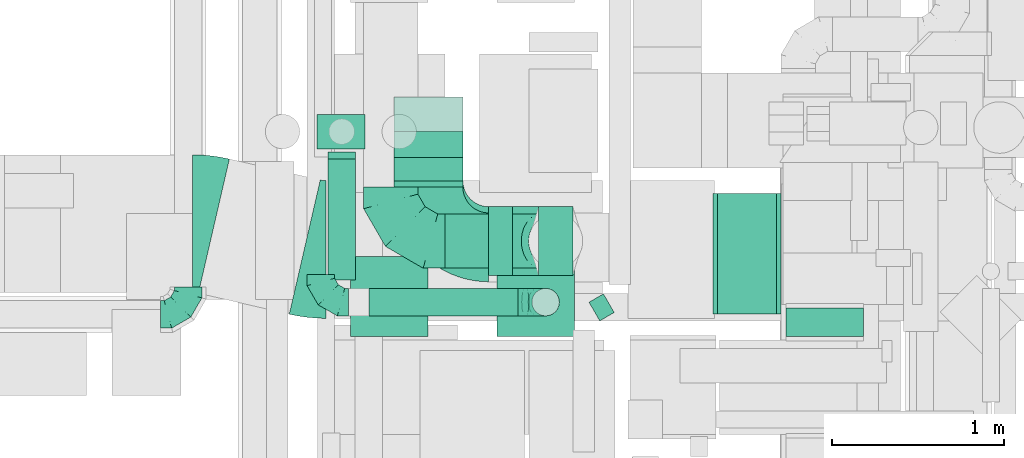
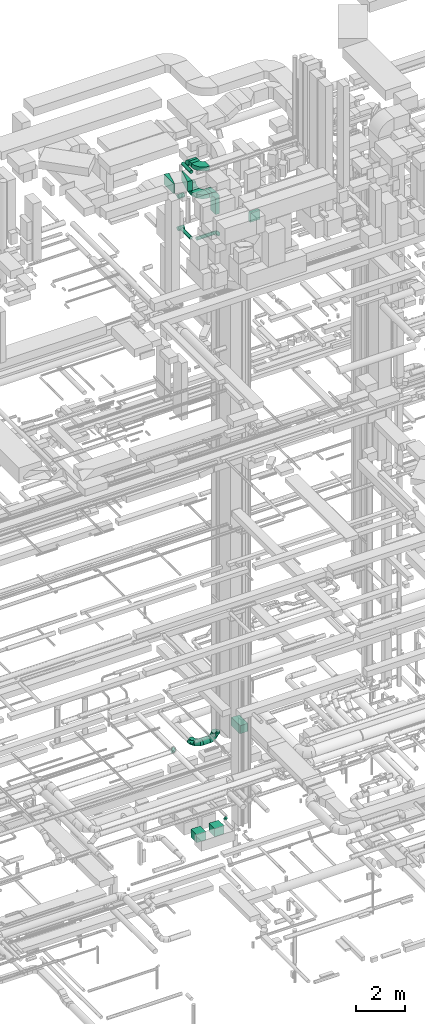
# One storey, part 176 of 337: 15 flow fittings, 15 flow segments.
"""IFC2X3 building model written with IfcOpenShell, lengths in millimetres."""

from ifc_helpers import new_model, entity, si_unit, converted_unit, derived_unit, direction, frame, frame_2d, origin, origin_2d_with_axis, place, context, subcontext, project, spatial, polyline, circle_curve, parameter, trimmed, segment, composite_curve, rectangle, circle, outline, extrude, faceted_brep, source, transform, mapped, material, type_object, type_shapes, element, save


model = new_model("IFC2X3")

# Units and contexts
model_context = context("Model", 3, precision=0.01, world=origin(), true_north=direction((6.12303176911189e-17, 1.0)))
body_context = subcontext(model_context, "Body", "Model", "MODEL_VIEW")
ifc_project = project(units=[si_unit("LENGTHUNIT", "METRE", prefix="MILLI"), si_unit("AREAUNIT", "SQUARE_METRE"), si_unit("VOLUMEUNIT", "CUBIC_METRE"), converted_unit("PLANEANGLEUNIT", "DEGREE", entity("IfcRatioMeasure", 0.0174532925199433), si_unit("PLANEANGLEUNIT", "RADIAN"), dimensions=[0, 0, 0, 0, 0, 0, 0]), si_unit("MASSUNIT", "GRAM", prefix="KILO"), derived_unit("MASSDENSITYUNIT", [(si_unit("MASSUNIT", "GRAM", prefix="KILO"), 1), (si_unit("LENGTHUNIT", "METRE"), -3)]), derived_unit("MOMENTOFINERTIAUNIT", [(si_unit("LENGTHUNIT", "METRE"), 4)]), si_unit("TIMEUNIT", "SECOND"), si_unit("FREQUENCYUNIT", "HERTZ"), si_unit("THERMODYNAMICTEMPERATUREUNIT", "DEGREE_CELSIUS"), derived_unit("THERMALTRANSMITTANCEUNIT", [(si_unit("MASSUNIT", "GRAM", prefix="KILO"), 1), (si_unit("THERMODYNAMICTEMPERATUREUNIT", "KELVIN"), -1), (si_unit("TIMEUNIT", "SECOND"), -3)]), derived_unit("VOLUMETRICFLOWRATEUNIT", [(si_unit("LENGTHUNIT", "METRE"), 3), (si_unit("TIMEUNIT", "SECOND"), -1)]), derived_unit("MASSFLOWRATEUNIT", [(si_unit("MASSUNIT", "GRAM", prefix="KILO"), 1), (si_unit("TIMEUNIT", "SECOND"), -1)]), derived_unit("ROTATIONALFREQUENCYUNIT", [(si_unit("TIMEUNIT", "SECOND"), -1)]), si_unit("ELECTRICCURRENTUNIT", "AMPERE"), si_unit("ELECTRICVOLTAGEUNIT", "VOLT"), si_unit("POWERUNIT", "WATT"), si_unit("FORCEUNIT", "NEWTON", prefix="KILO"), si_unit("ILLUMINANCEUNIT", "LUX"), si_unit("LUMINOUSFLUXUNIT", "LUMEN"), si_unit("LUMINOUSINTENSITYUNIT", "CANDELA"), derived_unit("USERDEFINED", [(si_unit("MASSUNIT", "GRAM", prefix="KILO"), -1), (si_unit("LENGTHUNIT", "METRE"), -2), (si_unit("TIMEUNIT", "SECOND"), 3), (si_unit("LUMINOUSFLUXUNIT", "LUMEN"), 1)]), derived_unit("LINEARVELOCITYUNIT", [(si_unit("LENGTHUNIT", "METRE"), 1), (si_unit("TIMEUNIT", "SECOND"), -1)]), si_unit("PRESSUREUNIT", "PASCAL"), derived_unit("USERDEFINED", [(si_unit("LENGTHUNIT", "METRE"), -2), (si_unit("MASSUNIT", "GRAM", prefix="KILO"), 1), (si_unit("TIMEUNIT", "SECOND"), -2)]), derived_unit("LINEARFORCEUNIT", [(si_unit("MASSUNIT", "GRAM", prefix="KILO"), 1), (si_unit("LENGTHUNIT", "METRE"), 1), (si_unit("TIMEUNIT", "SECOND"), -2), (si_unit("LENGTHUNIT", "METRE"), -1)]), derived_unit("PLANARFORCEUNIT", [(si_unit("MASSUNIT", "GRAM", prefix="KILO"), 1), (si_unit("LENGTHUNIT", "METRE"), 1), (si_unit("TIMEUNIT", "SECOND"), -2), (si_unit("LENGTHUNIT", "METRE"), -2)])], contexts=[model_context])

# Site, building, storey
site_placement = place(None, origin())
site = spatial("IfcSite", under=ifc_project, at=site_placement, CompositionType="ELEMENT")
building_placement = place(site_placement, origin())
building = spatial("IfcBuilding", under=site, at=building_placement, CompositionType="ELEMENT")
storey_placement = place(building_placement, origin())
storey = spatial("IfcBuildingStorey", under=building, at=storey_placement, CompositionType="ELEMENT", Elevation=0.0)

# Flow segments
duct_segment_type_1 = type_object("IfcDuctSegmentType", PredefinedType="NOTDEFINED")
flow_segment_1_placement = place(storey_placement, frame((44232.27, 11784.6, -1300.0)))
element("IfcFlowSegment", 1, at=flow_segment_1_placement, inside=storey, type_object=duct_segment_type_1, context=body_context, shape_type="SweptSolid", body=[
    extrude(rectangle(XDim=463.717020003643, YDim=450.000000000002, at=origin_2d_with_axis()), frame((225.0, 231.86, 0.0), z_axis=(0.0, 0.0, 1.0), x_axis=(0.0, 1.0, 0.0)), (0.0, 0.0, 1.0), 400.0),
])
flow_segment_2_placement = place(storey_placement, frame((43382.27, 11784.6, -1300.0)))
element("IfcFlowSegment", 2, at=flow_segment_2_placement, inside=storey, type_object=duct_segment_type_1, context=body_context, shape_type="SweptSolid", body=[
    extrude(rectangle(XDim=463.717020003613, YDim=450.000000000002, at=origin_2d_with_axis()), frame((225.0, 231.86, 0.0), z_axis=(0.0, 0.0, 1.0), x_axis=(0.0, 1.0, 0.0)), (0.0, 0.0, 1.0), 400.0),
])
flow_segment_3_placement = place(storey_placement, frame((45515.05, 11913.72, 3300.0)))
element("IfcFlowSegment", 3, at=flow_segment_3_placement, inside=storey, type_object=duct_segment_type_1, context=body_context, shape_type="SweptSolid", body=[
    extrude(rectangle(XDim=340.793808090526, YDim=700.000000000001, at=origin_2d_with_axis()), frame((170.4, 350.0, 0.0)), (0.0, 0.0, 1.0), 400.0),
])
flow_segment_4_placement = place(storey_placement, frame((44473.69, 12138.29, 29350.24)))
element("IfcFlowSegment", 4, at=flow_segment_4_placement, inside=storey, type_object=duct_segment_type_1, context=body_context, shape_type="SweptSolid", body=[
    extrude(rectangle(XDim=400.0, YDim=199.999999999998, at=origin_2d_with_axis()), frame((100.0, 200.0, 0.0), z_axis=(0.0, 0.0, 1.0), x_axis=(0.0, -1.0, 0.0)), (0.0, 0.0, 1.0), 799.758299470746),
])
flow_segment_5_placement = place(storey_placement, frame((44185.05, 12138.29, 30300.0)))
element("IfcFlowSegment", 5, at=flow_segment_5_placement, inside=storey, type_object=duct_segment_type_1, context=body_context, shape_type="SweptSolid", body=[
    extrude(rectangle(XDim=138.646095000015, YDim=400.0, at=origin_2d_with_axis()), frame((69.32, 200.0, 0.0), z_axis=(0.0, 0.0, 1.0), x_axis=(-1.0, 0.0, 0.0)), (0.0, 0.0, 1.0), 199.999999999998),
])
flow_segment_6_placement = place(storey_placement, frame((43635.05, 12688.29, 30300.0)))
element("IfcFlowSegment", 6, at=flow_segment_6_placement, inside=storey, type_object=duct_segment_type_1, context=body_context, shape_type="SweptSolid", body=[
    extrude(rectangle(XDim=136.304100000002, YDim=400.000000000004, at=origin_2d_with_axis()), frame((200.0, 68.15, 0.0), z_axis=(0.0, 0.0, 1.0), x_axis=(0.0, 1.0, 0.0)), (0.0, 0.0, 1.0), 199.999999999998),
])
flow_segment_7_placement = place(storey_placement, frame((43635.05, 12651.84, 31700.0)))
element("IfcFlowSegment", 7, at=flow_segment_7_placement, inside=storey, type_object=duct_segment_type_1, context=body_context, shape_type="SweptSolid", body=[
    extrude(rectangle(XDim=172.721155544705, YDim=399.999999999996, at=origin_2d_with_axis()), frame((200.01, 86.39, 0.0), z_axis=(0.0, 0.0, 1.0), x_axis=(0.000143096276811806, -0.999999989761728, 0.0)), (0.0, 0.0, 1.0), 199.999999999998),
])
flow_segment_8_placement = place(storey_placement, frame((45911.4, 11784.6, 28680.0)))
element("IfcFlowSegment", 8, at=flow_segment_8_placement, inside=storey, type_object=duct_segment_type_1, context=body_context, shape_type="SweptSolid", body=[
    extrude(rectangle(XDim=165.999999999997, YDim=450.000000000002, at=origin_2d_with_axis()), frame((225.0, 83.0, 0.0), z_axis=(0.0, 0.0, 1.0), x_axis=(0.0, -1.0, 0.0)), (0.0, 0.0, 1.0), 450.000000000002),
])
duct_segment_type_2 = type_object("IfcDuctSegmentType", PredefinedType="NOTDEFINED")
flow_segment_9_placement = place(storey_placement, frame((44765.88, 11873.59, -764.1)))
element("IfcFlowSegment", 9, at=flow_segment_9_placement, inside=storey, type_object=duct_segment_type_2, context=body_context, shape_type="SweptSolid", body=[
    extrude(circle(Radius=62.5, at=origin_2d_with_axis()), frame((32.85, 55.72, 64.1), z_axis=(0.866025210844138, 0.500000334182255, 0.0), x_axis=(0.500000334182255, -0.866025210844138, 0.0)), (0.0, 0.0, 1.0), 96.8997079406681),
])
flow_segment_10_placement = place(storey_placement, frame((43931.18, 12179.19, 3040.9)))
element("IfcFlowSegment", 10, at=flow_segment_10_placement, inside=storey, type_object=duct_segment_type_2, context=body_context, shape_type="SweptSolid", body=[
    extrude(circle(Radius=157.5, at=origin_2d_with_axis()), frame((0.0, 159.1, 159.1), z_axis=(1.0, 0.0, 0.0), x_axis=(0.0, -1.0, 0.0)), (0.0, 0.0, 1.0), 327.509169479983),
])
flow_segment_11_placement = place(storey_placement, frame((43249.45, 12113.77, 31818.4)))
element("IfcFlowSegment", 11, at=flow_segment_11_placement, inside=storey, type_object=duct_segment_type_2, context=body_context, shape_type="SweptSolid", body=[
    extrude(circle(Radius=80.0, at=origin_2d_with_axis()), frame((81.6, 0.0, 81.6), z_axis=(0.0, 1.0, 0.0), x_axis=(1.0, 0.0, 0.0)), (0.0, 0.0, 1.0), 700.818974375727),
])
flow_segment_12_placement = place(storey_placement, frame((43187.72, 12873.0, 30097.55)))
element("IfcFlowSegment", 12, at=flow_segment_12_placement, inside=storey, type_object=duct_segment_type_2, context=body_context, shape_type="SweptSolid", body=[
    extrude(circle(Radius=100.0, at=origin_2d_with_axis()), frame((0.0, 101.6, 101.6), z_axis=(1.0, 0.0, 0.0), x_axis=(0.0, -1.0, 0.0)), (0.0, 0.0, 1.0), 277.509200000024),
])
flow_segment_13_placement = place(storey_placement, frame((43187.72, 12873.0, 28497.55)))
element("IfcFlowSegment", 13, at=flow_segment_13_placement, inside=storey, type_object=duct_segment_type_2, context=body_context, shape_type="SweptSolid", body=[
    extrude(circle(Radius=100.0, at=origin_2d_with_axis()), frame((0.0, 101.6, 101.6), z_axis=(1.0, 0.0, 0.0), x_axis=(0.0, 1.0, 0.0)), (0.0, 0.0, 1.0), 277.509200000024),
])
flow_segment_14_placement = place(storey_placement, frame((43491.04, 11902.28, 28518.4)))
element("IfcFlowSegment", 14, at=flow_segment_14_placement, inside=storey, type_object=duct_segment_type_2, context=body_context, shape_type="SweptSolid", body=[
    extrude(circle(Radius=80.0, at=origin_2d_with_axis()), frame((0.0, 81.6, 81.6), z_axis=(1.0, 0.0, 0.0), x_axis=(0.0, 1.0, 0.0)), (0.0, 0.0, 1.0), 864.201436888467),
])
flow_segment_15_placement = place(storey_placement, frame((43249.45, 12143.87, 28518.4)))
element("IfcFlowSegment", 15, at=flow_segment_15_placement, inside=storey, type_object=duct_segment_type_2, context=body_context, shape_type="SweptSolid", body=[
    extrude(circle(Radius=80.0, at=origin_2d_with_axis()), frame((81.6, 0.0, 81.6), z_axis=(0.0, 1.0, 0.0), x_axis=(-1.0, 0.0, 0.0)), (0.0, 0.0, 1.0), 710.724934383916),
])

# Flow fittings
ifc_material = material()
duct_fitting_type_1 = type_object("IfcDuctFittingType", PredefinedType="NOTDEFINED", material=ifc_material)
shared_shape_1 = source(origin(), body_context, "Body", "SweptSolid", [
    extrude(rectangle(XDim=700.0, YDim=26.096, at=origin_2d_with_axis()), frame((6.95, 0.0, -200.0), z_axis=(0.0, 0.0, 1.0), x_axis=(0.0, -1.0, 0.0)), (0.0, 0.0, 1.0), 400.0),
])
type_shapes(duct_fitting_type_1, [shared_shape_1])
flow_fitting_1_placement = place(storey_placement, frame((45875.84, 12263.72, 3500.0), z_axis=(0.0, 0.0, -1.0), x_axis=(-1.0, 0.0, 0.0)))
element("IfcFlowFitting", 16, at=flow_fitting_1_placement, inside=storey, type_object=duct_fitting_type_1, material=ifc_material, context=body_context, shape_type="MappedRepresentation", body=[
    mapped(shared_shape_1, transform((0.0, 0.0, 0.0), scale=1.0)),
])
duct_fitting_type_2 = type_object("IfcDuctFittingType", PredefinedType="NOTDEFINED", material=ifc_material)
shared_shape_2 = source(origin(), body_context, "Body", "SweptSolid", [
    extrude(rectangle(XDim=26.0960000000006, YDim=400.0, at=origin_2d_with_axis()), frame((6.95, 0.0, -350.0)), (0.0, 0.0, 1.0), 700.0),
])
type_shapes(duct_fitting_type_2, [shared_shape_2])
flow_fitting_2_placement = place(storey_placement, frame((45495.05, 12263.72, 3500.0), z_axis=(0.0, -1.0, 0.0), x_axis=(1.0, 0.0, 0.0)))
element("IfcFlowFitting", 17, at=flow_fitting_2_placement, inside=storey, type_object=duct_fitting_type_2, material=ifc_material, context=body_context, shape_type="MappedRepresentation", body=[
    mapped(shared_shape_2, transform((0.0, 0.0, 0.0), scale=1.0)),
])
duct_fitting_type_3 = type_object("IfcDuctFittingType", PredefinedType="NOTDEFINED", material=ifc_material)
shared_shape_3 = source(origin(), body_context, "Body", "Brep", [
    faceted_brep([(-160.0, 0.0, -80.0), (-160.0, -20.71, -77.27), (-160.0, -40.0, -69.28), (-160.0, -56.57, -56.57), (-160.0, -69.28, -40.0), (-160.0, -77.27, -20.71), (-160.0, -80.0, 0.0), (-160.0, -77.27, 20.71), (-160.0, -69.28, 40.0), (-160.0, -56.57, 56.57), (-160.0, -40.0, 69.28), (-160.0, -20.71, 77.27), (-160.0, 0.0, 80.0), (-160.0, 20.71, 77.27), (-160.0, 40.0, 69.28), (-160.0, 56.57, 56.57), (-160.0, 69.28, 40.0), (-160.0, 77.27, 20.71), (-160.0, 80.0, 0.0), (-160.0, 77.27, -20.71), (-160.0, 69.28, -40.0), (-160.0, 56.57, -56.57), (-160.0, 40.0, -69.28), (-160.0, 20.71, -77.27), (-122.68, 20.71, 77.27), (-127.85, 40.0, 69.28), (-117.13, 0.0, 80.0), (-132.29, 56.57, 56.57), (-137.83, 77.27, 20.71), (-138.56, 80.0, 0.0), (-135.69, 69.28, 40.0), (-135.69, 69.28, -40.0), (-132.29, 56.57, -56.57), (-137.83, 77.27, -20.71), (-122.68, 20.71, -77.27), (-117.13, 0.0, -80.0), (-127.85, 40.0, -69.28), (-111.58, -20.71, -77.27), (-106.41, -40.0, -69.28), (-101.97, -56.57, -56.57), (-98.56, -69.28, -40.0), (-96.42, -77.27, -20.71), (-95.69, -80.0, 0.0), (-96.42, -77.27, 20.71), (-98.56, -69.28, 40.0), (-101.97, -56.57, 56.57), (-106.41, -40.0, 69.28), (-111.58, -20.71, 77.27), (-58.03, 58.03, 77.27), (-72.15, 72.15, 69.28), (-42.87, 42.87, 80.0), (-84.28, 84.28, 56.57), (-93.59, 93.59, 40.0), (-99.44, 99.44, 20.71), (-101.44, 101.44, 0.0), (-99.44, 99.44, -20.71), (-93.59, 93.59, -40.0), (-84.28, 84.28, -56.57), (-58.03, 58.03, -77.27), (-42.87, 42.87, -80.0), (-72.15, 72.15, -69.28), (-27.71, 27.71, -77.27), (-13.59, 13.59, -69.28), (-1.46, 1.46, -56.57), (7.85, -7.85, -40.0), (13.7, -13.7, -20.71), (15.69, -15.69, 0.0), (13.7, -13.7, 20.71), (7.85, -7.85, 40.0), (-1.46, 1.46, 56.57), (-13.59, 13.59, 69.28), (-27.71, 27.71, 77.27), (-20.71, 122.68, 77.27), (-40.0, 127.85, 69.28), (0.0, 117.13, 80.0), (-56.57, 132.29, 56.57), (-69.28, 135.69, 40.0), (-77.27, 137.83, 20.71), (-80.0, 138.56, 0.0), (-77.27, 137.83, -20.71), (-69.28, 135.69, -40.0), (-56.57, 132.29, -56.57), (-20.71, 122.68, -77.27), (0.0, 117.13, -80.0), (-40.0, 127.85, -69.28), (20.71, 111.58, -77.27), (40.0, 106.41, -69.28), (56.57, 101.97, -56.57), (69.28, 98.56, -40.0), (77.27, 96.42, -20.71), (80.0, 95.69, 0.0), (77.27, 96.42, 20.71), (69.28, 98.56, 40.0), (56.57, 101.97, 56.57), (40.0, 106.41, 69.28), (20.71, 111.58, 77.27), (-20.71, 160.0, -77.27), (-40.0, 160.0, -69.28), (-56.57, 160.0, -56.57), (-69.28, 160.0, -40.0), (-77.27, 160.0, -20.71), (-80.0, 160.0, 0.0), (-77.27, 160.0, 20.71), (-69.28, 160.0, 40.0), (-56.57, 160.0, 56.57), (-40.0, 160.0, 69.28), (-20.71, 160.0, 77.27), (0.0, 160.0, 80.0), (20.71, 160.0, 77.27), (40.0, 160.0, 69.28), (56.57, 160.0, 56.57), (69.28, 160.0, 40.0), (77.27, 160.0, 20.71), (80.0, 160.0, 0.0), (77.27, 160.0, -20.71), (69.28, 160.0, -40.0), (56.57, 160.0, -56.57), (40.0, 160.0, -69.28), (20.71, 160.0, -77.27), (0.0, 160.0, -80.0)], [[[0, 1, 2, 3, 4, 5, 6, 7, 8, 9, 10, 11, 12, 13, 14, 15, 16, 17, 18, 19, 20, 21, 22, 23]], [[24, 25, 14, 13]], [[26, 24, 13, 12]], [[14, 25, 27, 15]], [[28, 29, 18, 17]], [[30, 28, 17, 16]], [[15, 27, 30, 16]], [[20, 31, 32, 21]], [[33, 31, 20, 19]], [[18, 29, 33, 19]], [[34, 35, 0, 23]], [[36, 34, 23, 22]], [[32, 36, 22, 21]], [[1, 0, 35, 37]], [[2, 1, 37, 38]], [[3, 2, 38, 39]], [[5, 4, 40, 41]], [[6, 5, 41, 42]], [[39, 40, 4, 3]], [[6, 42, 43, 7]], [[7, 43, 44, 8]], [[8, 44, 45, 9]], [[9, 45, 46, 10]], [[10, 46, 47, 11]], [[26, 12, 11, 47]], [[48, 49, 25, 24]], [[50, 48, 24, 26]], [[27, 25, 49, 51]], [[52, 53, 28, 30]], [[51, 52, 30, 27]], [[29, 28, 53, 54]], [[55, 56, 31, 33]], [[54, 55, 33, 29]], [[32, 31, 56, 57]], [[58, 59, 35, 34]], [[60, 58, 34, 36]], [[57, 60, 36, 32]], [[37, 35, 59, 61]], [[38, 37, 61, 62]], [[39, 38, 62, 63]], [[41, 40, 64, 65]], [[42, 41, 65, 66]], [[63, 64, 40, 39]], [[43, 42, 66, 67]], [[44, 43, 67, 68]], [[68, 69, 45, 44]], [[46, 45, 69, 70]], [[47, 46, 70, 71]], [[26, 47, 71, 50]], [[72, 73, 49, 48]], [[74, 72, 48, 50]], [[51, 49, 73, 75]], [[76, 77, 53, 52]], [[75, 76, 52, 51]], [[54, 53, 77, 78]], [[79, 80, 56, 55]], [[78, 79, 55, 54]], [[57, 56, 80, 81]], [[82, 83, 59, 58]], [[84, 82, 58, 60]], [[81, 84, 60, 57]], [[61, 59, 83, 85]], [[62, 61, 85, 86]], [[63, 62, 86, 87]], [[65, 64, 88, 89]], [[66, 65, 89, 90]], [[87, 88, 64, 63]], [[67, 66, 90, 91]], [[68, 67, 91, 92]], [[92, 93, 69, 68]], [[70, 69, 93, 94]], [[71, 70, 94, 95]], [[50, 71, 95, 74]], [[96, 97, 98, 99, 100, 101, 102, 103, 104, 105, 106, 107, 108, 109, 110, 111, 112, 113, 114, 115, 116, 117, 118, 119]], [[72, 74, 107, 106]], [[73, 72, 106, 105]], [[75, 73, 105, 104]], [[77, 76, 103, 102]], [[78, 77, 102, 101]], [[75, 104, 103, 76]], [[78, 101, 100, 79]], [[79, 100, 99, 80]], [[80, 99, 98, 81]], [[84, 97, 96, 82]], [[82, 96, 119, 83]], [[84, 81, 98, 97]], [[118, 117, 86, 85]], [[119, 118, 85, 83]], [[116, 87, 86, 117]], [[88, 115, 114, 89]], [[89, 114, 113, 90]], [[115, 88, 87, 116]], [[112, 111, 92, 91]], [[113, 112, 91, 90]], [[111, 110, 93, 92]], [[95, 94, 109, 108]], [[74, 95, 108, 107]], [[110, 109, 94, 93]]]),
])
type_shapes(duct_fitting_type_3, [shared_shape_3])
flow_fitting_3_placement = place(storey_placement, frame((42439.16, 11912.65, 3550.0)))
element("IfcFlowFitting", 18, at=flow_fitting_3_placement, inside=storey, type_object=duct_fitting_type_3, material=ifc_material, context=body_context, shape_type="MappedRepresentation", body=[
    mapped(shared_shape_3, transform((0.0, 0.0, 0.0), scale=1.0)),
])
for number, where, z_axis, x_axis in (
    (19, (44515.25, 11983.87, 3600.0), (0.0, -1.0, 0.0), (1.0, 0.0, 0.0)),
    (20, (43210.25, 11983.87, 3600.0), (0.0, 0.0, 1.0), (0.0, -1.0, 0.0)),
    (21, (44515.25, 11983.87, 28600.0), (0.0, -1.0, 0.0), (0.0, 0.0, 1.0)),
):
    element("IfcFlowFitting", number, at=place(storey_placement, frame(where, z_axis=z_axis, x_axis=x_axis)), inside=storey, type_object=duct_fitting_type_3, material=ifc_material, context=body_context, shape_type="MappedRepresentation", body=[
        mapped(shared_shape_3, transform((0.0, 0.0, 0.0), scale=1.0)),
    ])
duct_fitting_type_4 = type_object("IfcDuctFittingType", PredefinedType="NOTDEFINED", material=ifc_material)
shared_shape_4 = source(origin(), body_context, "Body", "Brep", [
    faceted_brep([(-315.0, 0.0, -157.5), (-315.0, -40.76, -152.13), (-315.0, -78.75, -136.4), (-315.0, -111.37, -111.37), (-315.0, -136.4, -78.75), (-315.0, -152.13, -40.76), (-315.0, -157.5, 0.0), (-315.0, -152.13, 40.76), (-315.0, -136.4, 78.75), (-315.0, -111.37, 111.37), (-315.0, -78.75, 136.4), (-315.0, -40.76, 152.13), (-315.0, 0.0, 157.5), (-315.0, 40.76, 152.13), (-315.0, 78.75, 136.4), (-315.0, 111.37, 111.37), (-315.0, 136.4, 78.75), (-315.0, 152.13, 40.76), (-315.0, 157.5, 0.0), (-315.0, 152.13, -40.76), (-315.0, 136.4, -78.75), (-315.0, 111.37, -111.37), (-315.0, 78.75, -136.4), (-315.0, 40.76, -152.13), (-241.52, 40.76, 152.13), (-251.7, 78.75, 136.4), (-230.6, 0.0, 157.5), (-260.44, 111.37, 111.37), (-271.36, 152.13, 40.76), (-272.8, 157.5, 0.0), (-267.14, 136.4, 78.75), (-267.14, 136.4, -78.75), (-260.44, 111.37, -111.37), (-271.36, 152.13, -40.76), (-241.52, 40.76, -152.13), (-230.6, 0.0, -157.5), (-251.7, 78.75, -136.4), (-219.67, -40.76, -152.13), (-209.5, -78.75, -136.4), (-200.75, -111.37, -111.37), (-194.05, -136.4, -78.75), (-189.83, -152.13, -40.76), (-188.39, -157.5, 0.0), (-189.83, -152.13, 40.76), (-194.05, -136.4, 78.75), (-200.75, -111.37, 111.37), (-209.5, -78.75, 136.4), (-219.67, -40.76, 152.13), (-114.25, 114.25, 152.13), (-142.05, 142.05, 136.4), (-84.4, 84.4, 157.5), (-165.93, 165.93, 111.37), (-184.25, 184.25, 78.75), (-195.77, 195.77, 40.76), (-199.7, 199.7, 0.0), (-195.77, 195.77, -40.76), (-184.25, 184.25, -78.75), (-165.93, 165.93, -111.37), (-114.25, 114.25, -152.13), (-84.4, 84.4, -157.5), (-142.05, 142.05, -136.4), (-54.56, 54.56, -152.13), (-26.75, 26.75, -136.4), (-2.88, 2.88, -111.37), (15.45, -15.45, -78.75), (26.97, -26.97, -40.76), (30.89, -30.89, 0.0), (26.97, -26.97, 40.76), (15.45, -15.45, 78.75), (-2.88, 2.88, 111.37), (-26.75, 26.75, 136.4), (-54.56, 54.56, 152.13), (-40.76, 241.52, 152.13), (-78.75, 251.7, 136.4), (0.0, 230.6, 157.5), (-111.37, 260.44, 111.37), (-136.4, 267.14, 78.75), (-152.13, 271.36, 40.76), (-157.5, 272.8, 0.0), (-152.13, 271.36, -40.76), (-136.4, 267.14, -78.75), (-111.37, 260.44, -111.37), (-40.76, 241.52, -152.13), (0.0, 230.6, -157.5), (-78.75, 251.7, -136.4), (40.76, 219.67, -152.13), (78.75, 209.5, -136.4), (111.37, 200.75, -111.37), (136.4, 194.05, -78.75), (152.13, 189.83, -40.76), (157.5, 188.39, 0.0), (152.13, 189.83, 40.76), (136.4, 194.05, 78.75), (111.37, 200.75, 111.37), (78.75, 209.5, 136.4), (40.76, 219.67, 152.13), (-40.76, 315.0, -152.13), (-78.75, 315.0, -136.4), (-111.37, 315.0, -111.37), (-136.4, 315.0, -78.75), (-152.13, 315.0, -40.76), (-157.5, 315.0, 0.0), (-152.13, 315.0, 40.76), (-136.4, 315.0, 78.75), (-111.37, 315.0, 111.37), (-78.75, 315.0, 136.4), (-40.76, 315.0, 152.13), (0.0, 315.0, 157.5), (40.76, 315.0, 152.13), (78.75, 315.0, 136.4), (111.37, 315.0, 111.37), (136.4, 315.0, 78.75), (152.13, 315.0, 40.76), (157.5, 315.0, 0.0), (152.13, 315.0, -40.76), (136.4, 315.0, -78.75), (111.37, 315.0, -111.37), (78.75, 315.0, -136.4), (40.76, 315.0, -152.13), (0.0, 315.0, -157.5)], [[[0, 1, 2, 3, 4, 5, 6, 7, 8, 9, 10, 11, 12, 13, 14, 15, 16, 17, 18, 19, 20, 21, 22, 23]], [[24, 25, 14, 13]], [[26, 24, 13, 12]], [[14, 25, 27, 15]], [[28, 29, 18, 17]], [[30, 28, 17, 16]], [[15, 27, 30, 16]], [[20, 31, 32, 21]], [[33, 31, 20, 19]], [[18, 29, 33, 19]], [[34, 35, 0, 23]], [[36, 34, 23, 22]], [[32, 36, 22, 21]], [[1, 0, 35, 37]], [[2, 1, 37, 38]], [[38, 39, 3, 2]], [[5, 4, 40, 41]], [[6, 5, 41, 42]], [[39, 40, 4, 3]], [[6, 42, 43, 7]], [[7, 43, 44, 8]], [[8, 44, 45, 9]], [[9, 45, 46, 10]], [[10, 46, 47, 11]], [[26, 12, 11, 47]], [[48, 49, 25, 24]], [[50, 48, 24, 26]], [[27, 25, 49, 51]], [[52, 53, 28, 30]], [[51, 52, 30, 27]], [[29, 28, 53, 54]], [[55, 56, 31, 33]], [[54, 55, 33, 29]], [[32, 31, 56, 57]], [[58, 59, 35, 34]], [[60, 58, 34, 36]], [[57, 60, 36, 32]], [[37, 35, 59, 61]], [[38, 37, 61, 62]], [[39, 38, 62, 63]], [[41, 40, 64, 65]], [[42, 41, 65, 66]], [[63, 64, 40, 39]], [[43, 42, 66, 67]], [[44, 43, 67, 68]], [[68, 69, 45, 44]], [[46, 45, 69, 70]], [[47, 46, 70, 71]], [[26, 47, 71, 50]], [[72, 73, 49, 48]], [[74, 72, 48, 50]], [[51, 49, 73, 75]], [[76, 77, 53, 52]], [[75, 76, 52, 51]], [[54, 53, 77, 78]], [[79, 80, 56, 55]], [[78, 79, 55, 54]], [[57, 56, 80, 81]], [[82, 83, 59, 58]], [[84, 82, 58, 60]], [[81, 84, 60, 57]], [[61, 59, 83, 85]], [[62, 61, 85, 86]], [[63, 62, 86, 87]], [[65, 64, 88, 89]], [[66, 65, 89, 90]], [[87, 88, 64, 63]], [[67, 66, 90, 91]], [[68, 67, 91, 92]], [[92, 93, 69, 68]], [[70, 69, 93, 94]], [[71, 70, 94, 95]], [[50, 71, 95, 74]], [[96, 97, 98, 99, 100, 101, 102, 103, 104, 105, 106, 107, 108, 109, 110, 111, 112, 113, 114, 115, 116, 117, 118, 119]], [[106, 105, 73, 72]], [[107, 106, 72, 74]], [[75, 73, 105, 104]], [[77, 76, 103, 102]], [[78, 77, 102, 101]], [[104, 103, 76, 75]], [[78, 101, 100, 79]], [[79, 100, 99, 80]], [[98, 81, 80, 99]], [[84, 97, 96, 82]], [[82, 96, 119, 83]], [[97, 84, 81, 98]], [[83, 119, 118, 85]], [[85, 118, 117, 86]], [[116, 87, 86, 117]], [[88, 115, 114, 89]], [[89, 114, 113, 90]], [[115, 88, 87, 116]], [[91, 90, 113, 112]], [[92, 91, 112, 111]], [[111, 110, 93, 92]], [[95, 94, 109, 108]], [[74, 95, 108, 107]], [[110, 109, 94, 93]]]),
])
type_shapes(duct_fitting_type_4, [shared_shape_4])
for number, where, z_axis, x_axis in (
    (22, (43616.18, 12338.29, 3200.0), (0.0, 0.0, 1.0), (0.0, -1.0, 0.0)),
    (23, (44573.69, 12338.29, 3200.0), (0.0, -1.0, 0.0), (1.0, 0.0, 0.0)),
):
    element("IfcFlowFitting", number, at=place(storey_placement, frame(where, z_axis=z_axis, x_axis=x_axis)), inside=storey, type_object=duct_fitting_type_4, material=ifc_material, context=body_context, shape_type="MappedRepresentation", body=[
        mapped(shared_shape_4, transform((0.0, 0.0, 0.0), scale=1.0)),
    ])
duct_fitting_type_5 = type_object("IfcDuctFittingType", PredefinedType="NOTDEFINED", material=ifc_material)
shared_shape_5 = source(origin(), body_context, "Body", "SweptSolid", [
    extrude(outline(composite_curve([segment(polyline([(-375.0, -175.0), (25.0, -175.0)]), True, "CONTINUOUS"), segment(trimmed(circle_curve(frame_2d((175.0, -175.0), x_axis=(0.0, 1.0)), 150.0), [parameter(0.0)], [parameter(90.0000000000001)], True, "PARAMETER"), False, "CONTINUOUS"), segment(polyline([(175.0, -25.0), (175.0, 375.0)]), True, "CONTINUOUS"), segment(trimmed(circle_curve(frame_2d((175.0, -175.0), x_axis=(0.0, 1.0)), 550.0), [parameter(0.0)], [parameter(90.0)], True, "PARAMETER"), True, "CONTINUOUS")], self_intersect=False)), frame((-175.0, 175.0, -100.0), z_axis=(0.0, 0.0, 1.0), x_axis=(-1.0, 0.0, 0.0)), (0.0, 0.0, 1.0), 200.0),
])
type_shapes(duct_fitting_type_5, [shared_shape_5])
flow_fitting_4_placement = place(storey_placement, frame((43835.05, 12338.29, 30400.0), z_axis=(0.0, 0.0, 1.0), x_axis=(0.0, -1.0, 0.0)))
element("IfcFlowFitting", 24, at=flow_fitting_4_placement, inside=storey, type_object=duct_fitting_type_5, material=ifc_material, context=body_context, shape_type="MappedRepresentation", body=[
    mapped(shared_shape_5, transform((0.0, 0.0, 0.0), scale=1.0)),
])
duct_fitting_type_6 = type_object("IfcDuctFittingType", PredefinedType="NOTDEFINED", material=ifc_material)
shared_shape_6 = source(origin(), body_context, "Body", "SweptSolid", [
    extrude(outline(composite_curve([segment(polyline([(-225.0, -125.0), (-25.0, -125.0)]), True, "CONTINUOUS"), segment(trimmed(circle_curve(frame_2d((125.0, -125.0), x_axis=(0.0, 1.0)), 150.0), [parameter(0.0)], [parameter(90.0000000000001)], True, "PARAMETER"), False, "CONTINUOUS"), segment(polyline([(125.0, 25.0), (125.0, 225.0)]), True, "CONTINUOUS"), segment(trimmed(circle_curve(frame_2d((125.0, -125.0), x_axis=(0.0, 1.0)), 350.0), [parameter(0.0)], [parameter(90.0000000000001)], True, "PARAMETER"), True, "CONTINUOUS")], self_intersect=False)), frame((-125.0, 125.0, -200.0), z_axis=(0.0, 0.0, 1.0), x_axis=(-1.0, 0.0, 0.0)), (0.0, 0.0, 1.0), 400.0),
])
type_shapes(duct_fitting_type_6, [shared_shape_6])
for number, where, z_axis, x_axis in (
    (25, (44573.69, 12338.29, 30400.0), (0.0, -1.0, 0.0), (0.0, 0.0, 1.0)),
    (26, (43835.05, 13074.59, 30400.0), (1.0, 0.0, 0.0), (0.0, 1.0, 0.0)),
    (27, (43835.05, 13074.59, 31800.0), (1.0, 0.0, 0.0), (0.0, 0.0, 1.0)),
):
    element("IfcFlowFitting", number, at=place(storey_placement, frame(where, z_axis=z_axis, x_axis=x_axis)), inside=storey, type_object=duct_fitting_type_6, material=ifc_material, context=body_context, shape_type="MappedRepresentation", body=[
        mapped(shared_shape_6, transform((0.0, 0.0, 0.0), scale=1.0)),
    ])
duct_fitting_type_7 = type_object("IfcDuctFittingType", PredefinedType="NOTDEFINED", material=ifc_material)
shared_shape_7 = source(origin(), body_context, "Body", "SweptSolid", [
    extrude(outline(composite_curve([segment(polyline([(-407.05, -61.86), (392.95, -61.86)]), True, "CONTINUOUS"), segment(trimmed(circle_curve(frame_2d((542.95, -61.86), x_axis=(-0.974370064785234, 0.224951054343868)), 150.0), [parameter(0.0)], [parameter(13.0000000000002)], True, "PARAMETER"), False, "CONTINUOUS"), segment(polyline([(396.8, -28.12), (-382.7, 151.84)]), True, "CONTINUOUS"), segment(trimmed(circle_curve(frame_2d((542.95, -61.86), x_axis=(-0.974370064785234, 0.224951054343868)), 950.0), [parameter(0.0)], [parameter(13.0000000000002)], True, "PARAMETER"), True, "CONTINUOUS")], self_intersect=False)), frame((-0.8, 7.05, -250.0), z_axis=(0.0, 0.0, 1.0), x_axis=(-0.224951054343869, 0.974370064785234, 0.0)), (0.0, 0.0, 1.0), 500.0),
])
type_shapes(duct_fitting_type_7, [shared_shape_7])
for number, where, z_axis, x_axis in (
    (28, (42527.98, 12439.6, 31400.0), (0.0, 0.0, 1.0), (-0.974370064785234, 0.224951054343869, 0.0)),
    (29, (43177.71, 12289.6, 31400.0), (0.0, 0.0, 1.0), (0.974370064785227, -0.224951054343899, 0.0)),
):
    element("IfcFlowFitting", number, at=place(storey_placement, frame(where, z_axis=z_axis, x_axis=x_axis)), inside=storey, type_object=duct_fitting_type_7, material=ifc_material, context=body_context, shape_type="MappedRepresentation", body=[
        mapped(shared_shape_7, transform((0.0, 0.0, 0.0), scale=1.0)),
    ])
duct_fitting_type_8 = type_object("IfcDuctFittingType", PredefinedType="NOTDEFINED", material=ifc_material)
shared_shape_8 = source(origin(), body_context, "Body", "SweptSolid", [
    extrude(outline(composite_curve([segment(polyline([(-374.97, -175.0), (25.03, -175.0)]), True, "CONTINUOUS"), segment(trimmed(circle_curve(frame_2d((175.03, -175.0), x_axis=(-0.000143096276872257, 0.999999989761733)), 150.0), [parameter(0.0)], [parameter(89.9918011872427)], True, "PARAMETER"), False, "CONTINUOUS"), segment(polyline([(175.0, -25.0), (174.95, 375.0)]), True, "CONTINUOUS"), segment(trimmed(circle_curve(frame_2d((175.03, -175.0), x_axis=(-0.000143096276872257, 0.999999989761733)), 550.0), [parameter(0.0)], [parameter(89.9918011872427)], True, "PARAMETER"), True, "CONTINUOUS")], self_intersect=False)), frame((-174.95, 174.97, -100.0), z_axis=(0.0, 0.0, 1.0), x_axis=(-0.999999989761728, 0.000143096276882252, 0.0)), (0.0, 0.0, 1.0), 200.0),
])
type_shapes(duct_fitting_type_8, [shared_shape_8])
flow_fitting_5_placement = place(storey_placement, frame((43835.12, 12301.92, 31800.0), z_axis=(0.0, 0.0, 1.0), x_axis=(0.000143096276811806, -0.999999989761728, 0.0)))
element("IfcFlowFitting", 30, at=flow_fitting_5_placement, inside=storey, type_object=duct_fitting_type_8, material=ifc_material, context=body_context, shape_type="MappedRepresentation", body=[
    mapped(shared_shape_8, transform((0.0, 0.0, 0.0), scale=1.0)),
])

save(model, "model.ifc")
